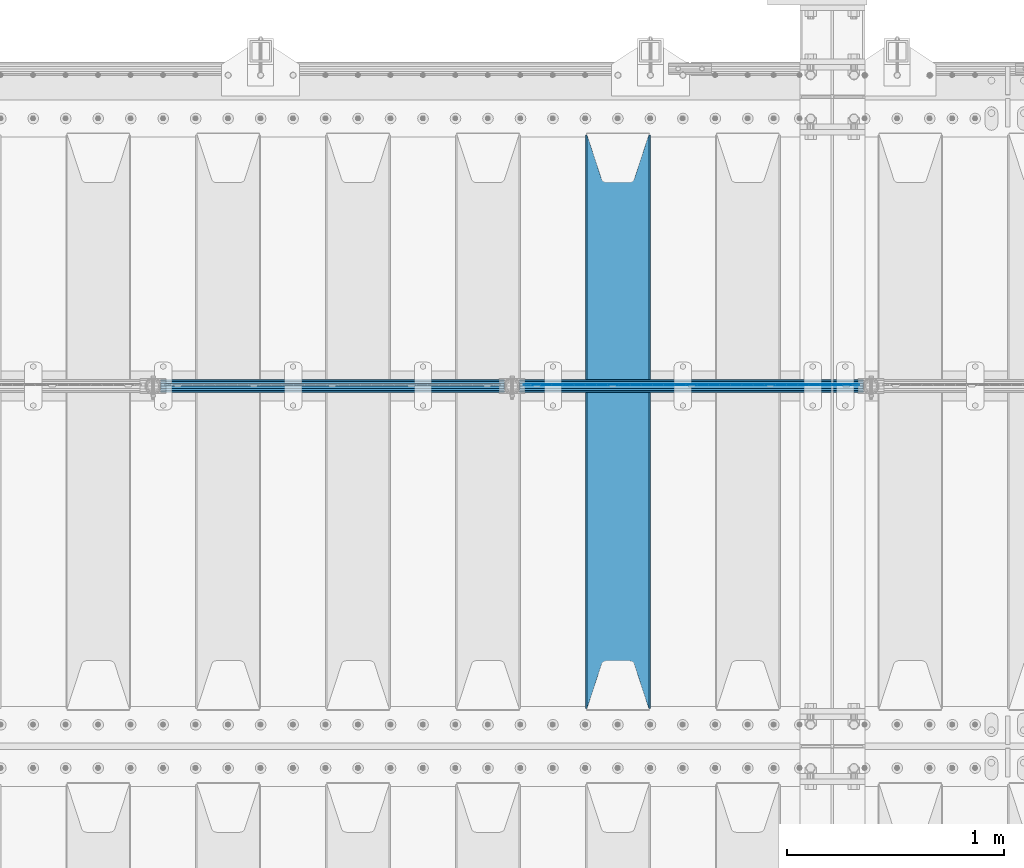
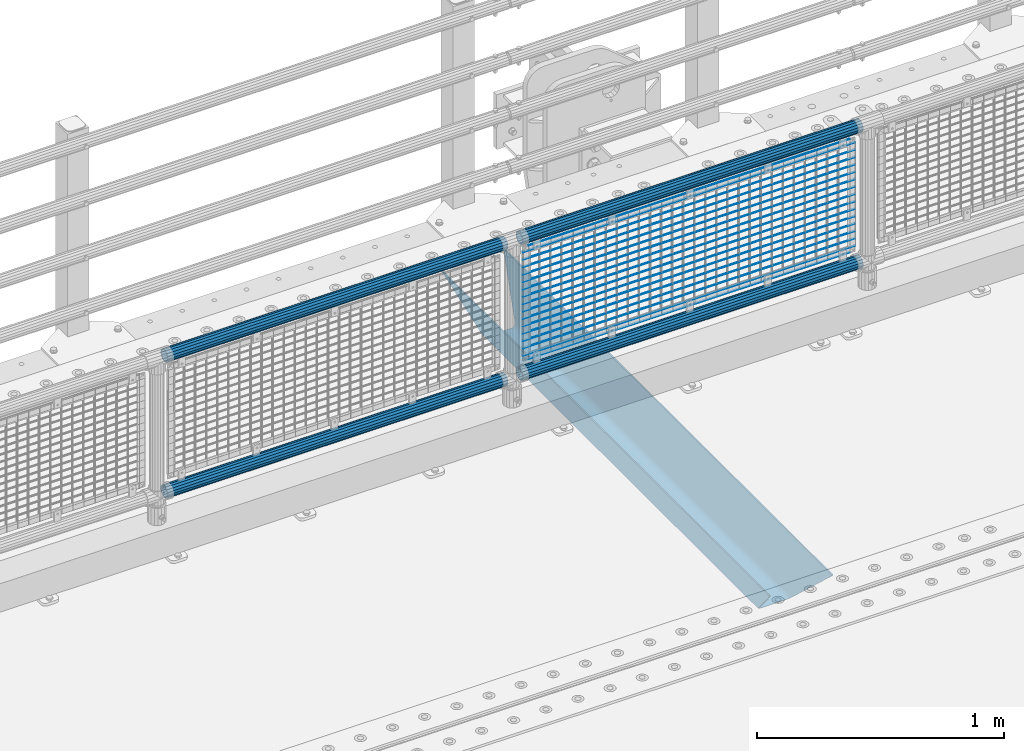
# One storey, part 122 of 240: 22 beams.
"""IFC2X3 building model written with IfcOpenShell, lengths in millimetres."""

from ifc_helpers import new_model, si_unit, frame, origin_with_axes, place, context, subcontext, project, spatial, faceted_brep, material, type_object, element, save


model = new_model("IFC2X3")

# Units and contexts
model_context = context("Model", 3, precision=1e-05, world=origin_with_axes())
body_context = subcontext(model_context, "Body", "Model", "MODEL_VIEW")
ifc_project = project(units=[si_unit("LENGTHUNIT", "METRE", prefix="MILLI"), si_unit("AREAUNIT", "SQUARE_METRE"), si_unit("VOLUMEUNIT", "CUBIC_METRE"), si_unit("MASSUNIT", "GRAM", prefix="KILO"), si_unit("TIMEUNIT", "SECOND"), si_unit("PLANEANGLEUNIT", "RADIAN"), si_unit("SOLIDANGLEUNIT", "STERADIAN"), si_unit("THERMODYNAMICTEMPERATUREUNIT", "DEGREE_CELSIUS"), si_unit("LUMINOUSINTENSITYUNIT", "LUMEN")], contexts=[model_context])

# Site, building, storey
site_placement = place(None, origin_with_axes())
site = spatial("IfcSite", under=ifc_project, at=site_placement, CompositionType="ELEMENT")
building_placement = place(site_placement, origin_with_axes())
building = spatial("IfcBuilding", under=site, at=building_placement, Name="Standard", CompositionType="ELEMENT")
storey_placement = place(building_placement, origin_with_axes())
storey = spatial("IfcBuildingStorey", under=building, at=storey_placement, Name="Undefined", CompositionType="ELEMENT", Elevation=0.0)

# Beams
ifc_material_1 = material(Name="STEEL/S355N")
beam_type_1 = type_object("IfcBeamType", PredefinedType="NOTDEFINED")
beam_1_placement = place(storey_placement, frame((51850.0, 33175.0, -115.0), z_axis=(0.0, 0.0, 1.0), x_axis=(0.0, 1.0, 0.0)))
element("IfcBeam", 1, at=beam_1_placement, inside=storey, type_object=beam_type_1, material=ifc_material_1, context=body_context, shape_type="Brep", body=[
    faceted_brep([(0.0, 150.0, 115.0), (0.0, 143.690000000002, 115.0), (2650.00000000297, 143.690000000002, 115.0), (2650.00000000297, 150.0, 115.0), (2650.00000000297, 142.059565218406, 110.000000003094), (2650.00000000297, 148.369565218403, 110.000000003094), (2441.90079219209, -80.1103600731149, -98.0992078077845), (2437.7588105432, -77.5672621345584, -102.241189456673), (2434.06523489747, -74.4080125315522, -105.934765102404), (2430.9108609509, -70.7102721255724, -109.089139048974), (2428.37322971128, -66.5649389910031, -111.626770288588), (2426.51472138055, -62.0739139532889, -113.485278619323), (2425.38102192092, -57.3475956567636, -114.618978078955), (2424.99999999987, -52.5021667386536, -115.0), (2424.99999999987, 52.5021667386536, -115.0), (2425.38102192092, 57.3475956567636, -114.618978078955), (2426.51472138055, 62.0739139532889, -113.485278619323), (2428.37322971128, 66.5649389910031, -111.626770288588), (2430.9108609509, 70.7102721255724, -109.089139048974), (2434.06523489747, 74.4080125315522, -105.934765102404), (2437.7588105432, 77.5672621345584, -102.241189456673), (2441.90079219209, 80.1103600731149, -98.0992078077846), (2446.38936140512, 81.9747917625791, -93.6106385947584), (2448.2494850041, 76.2713538057287, -91.7505149957729), (2444.62967112263, 74.76777986261, -95.3703288772456), (2441.28936334127, 72.7168944282894, -98.710636658607), (2438.31067330439, 70.1691124903809, -101.689326695487), (2435.76682334748, 67.1870637758839, -104.233176652398), (2433.72034654134, 63.8440531834931, -106.279653458539), (2432.22154950042, 60.2222587982324, -107.778450499454), (2431.30727574265, 56.4107117849126, -108.692724257221), (2430.99999999987, 52.5031078186876, -109.0), (2430.99999999987, -52.5031078186876, -109.0), (2431.30727574265, -56.4107117849126, -108.692724257221), (2432.22154950042, -60.2222587982324, -107.778450499454), (2433.72034654134, -63.8440531834931, -106.279653458539), (2435.76682334748, -67.1870637758839, -104.233176652398), (2438.31067330439, -70.1691124903809, -101.689326695487), (2441.28936334127, -72.7168944282894, -98.7106366586071), (2444.62967112263, -74.76777986261, -95.3703288772457), (2448.2494850041, -76.2713538057287, -91.7505149957729), (2650.00000000297, -142.059565218406, 110.000000003094), (2650.00000000297, -148.369565218403, 110.000000003094), (2446.38936140512, -81.9747917625791, -93.6106385947584), (2650.00000000297, -143.690000000002, 115.0), (2650.00000000297, -150.0, 115.0), (0.0, -143.690000000002, 115.0), (0.0, -150.0, 115.0), (0.0, -148.369565218258, 110.000000002667), (203.610638597427, -81.9747917625791, -93.6106385947584), (208.09920781045, -80.1103600731149, -98.0992078077845), (212.241189459342, -77.5672621345584, -102.241189456673), (215.93476510507, -74.4080125315522, -105.934765102404), (219.089139051641, -70.7102721255724, -109.089139048974), (221.626770291256, -66.5649389910031, -111.626770288588), (223.485278621989, -62.0739139532889, -113.485278619323), (224.618978081624, -57.3475956567636, -114.618978078955), (225.000000002663, -52.5021667386536, -115.0), (225.000000002663, 52.5021667386536, -115.0), (224.618978081624, 57.3475956567636, -114.618978078955), (223.485278621989, 62.0739139532889, -113.485278619323), (221.626770291256, 66.5649389910031, -111.626770288588), (219.089139051641, 70.7102721255724, -109.089139048974), (215.93476510507, 74.4080125315522, -105.934765102404), (212.241189459342, 77.5672621345584, -102.241189456673), (208.09920781045, 80.1103600731149, -98.0992078077846), (203.610638597427, 81.9747917625791, -93.6106385947584), (0.0, 148.369565218258, 110.000000002667), (0.0, 142.05956521826, 110.000000002667), (201.750514998439, 76.2713538057287, -91.7505149957729), (205.370328879908, 74.76777986261, -95.3703288772456), (208.710636661275, 72.7168944282894, -98.710636658607), (211.689326698153, 70.1691124903809, -101.689326695487), (214.233176655063, 67.1870637758839, -104.233176652398), (216.279653461206, 63.8440531834931, -106.279653458539), (217.778450502123, 60.2222587982324, -107.778450499454), (218.692724259887, 56.4107117849126, -108.692724257221), (219.000000002667, 52.5031078186876, -109.0), (219.000000002667, -52.5031078186876, -109.0), (218.692724259887, -56.4107117849126, -108.692724257221), (217.778450502123, -60.2222587982324, -107.778450499454), (216.279653461206, -63.8440531834931, -106.279653458539), (214.233176655063, -67.1870637758839, -104.233176652398), (211.689326698153, -70.1691124903809, -101.689326695487), (208.710636661275, -72.7168944282894, -98.7106366586071), (205.370328879915, -74.76777986261, -95.3703288772457), (201.750514998439, -76.2713538057287, -91.7505149957729), (0.0, -142.05956521826, 110.000000002667)], [[[0, 1, 2, 3]], [[3, 2, 4, 5]], [[6, 7, 8, 9, 10, 11, 12, 13, 14, 15, 16, 17, 18, 19, 20, 21, 22, 5, 4, 23, 24, 25, 26, 27, 28, 29, 30, 31, 32, 33, 34, 35, 36, 37, 38, 39, 40, 41, 42, 43]], [[44, 45, 42, 41]], [[46, 47, 45, 44]], [[43, 42, 45, 47, 48, 49]], [[6, 43, 49, 50]], [[7, 6, 50, 51]], [[8, 7, 51, 52]], [[9, 8, 52, 53]], [[10, 9, 53, 54]], [[11, 10, 54, 55]], [[12, 11, 55, 56]], [[13, 12, 56, 57]], [[14, 13, 57, 58]], [[15, 14, 58, 59]], [[16, 15, 59, 60]], [[17, 16, 60, 61]], [[18, 17, 61, 62]], [[19, 18, 62, 63]], [[20, 19, 63, 64]], [[21, 20, 64, 65]], [[22, 21, 65, 66]], [[0, 3, 5, 22, 66, 67]], [[1, 0, 67, 68]], [[23, 4, 2, 1, 68, 69]], [[24, 23, 69, 70]], [[25, 24, 70, 71]], [[26, 25, 71, 72]], [[27, 26, 72, 73]], [[28, 27, 73, 74]], [[29, 28, 74, 75]], [[30, 29, 75, 76]], [[31, 30, 76, 77]], [[32, 31, 77, 78]], [[33, 32, 78, 79]], [[34, 33, 79, 80]], [[35, 34, 80, 81]], [[36, 35, 81, 82]], [[37, 36, 82, 83]], [[38, 37, 83, 84]], [[39, 38, 84, 85]], [[40, 39, 85, 86]], [[46, 44, 41, 40, 86, 87]], [[47, 46, 87, 48]], [[86, 85, 84, 83, 82, 81, 80, 79, 78, 77, 76, 75, 74, 73, 72, 71, 70, 69, 68, 67, 66, 65, 64, 63, 62, 61, 60, 59, 58, 57, 56, 55, 54, 53, 52, 51, 50, 49, 48, 87]]]),
])
ifc_material_2 = material(Name="Misc_Undefined")
beam_type_2 = type_object("IfcBeamType", Name="D3", PredefinedType="NOTDEFINED")
for number, where, z_axis, x_axis in (
    (2, (51416.0, 34670.5, 851.597000000001), (0.0, 0.0, 1.0), (1.0, 0.0, 0.0)),
    (3, (51416.0, 34670.5, 669.452000000001), (0.0, 0.0, 1.0), (1.0, 0.0, 0.0)),
    (4, (51416.0, 34670.5, 523.736000000001), (0.0, 0.0, 1.0), (1.0, 0.0, 0.0)),
    (5, (51416.0, 34670.5, 487.307000000001), (0.0, 0.0, 1.0), (1.0, 0.0, 0.0)),
    (6, (51416.0, 34670.5, 705.881000000001), (0.0, 0.0, 1.0), (1.0, 0.0, 0.0)),
    (7, (51416.0, 34670.5, 596.594000000001), (0.0, 0.0, 1.0), (1.0, 0.0, 0.0)),
    (8, (51416.0, 34670.5, 450.878000000001), (0.0, 0.0, 1.0), (1.0, 0.0, 0.0)),
    (9, (51416.0, 34670.5, 815.168000000001), (0.0, 0.0, 1.0), (1.0, 0.0, 0.0)),
    (10, (51416.0, 34670.5, 888.026000000001), (0.0, 0.0, 1.0), (1.0, 0.0, 0.0)),
    (11, (51416.0, 34670.5, 778.739000000001), (0.0, 0.0, 1.0), (1.0, 0.0, 0.0)),
    (12, (51416.0, 34670.5, 742.310000000001), (0.0, 0.0, 1.0), (1.0, 0.0, 0.0)),
    (13, (51416.0, 34670.5, 633.023000000001), (0.0, 0.0, 1.0), (1.0, 0.0, 0.0)),
    (14, (51416.0, 34670.5, 560.165000000001), (0.0, 0.0, 1.0), (1.0, 0.0, 0.0)),
    (15, (51416.0, 34670.5, 414.449000000001), (0.0, 0.0, 1.0), (1.0, 0.0, 0.0)),
):
    element("IfcBeam", number, at=place(storey_placement, frame(where, z_axis=z_axis, x_axis=x_axis)), inside=storey, type_object=beam_type_2, material=ifc_material_2, ObjectType="D3", context=body_context, shape_type="Brep", body=[
        faceted_brep([(-7.27595761418343e-12, -1.49999999999272, 0.0), (-7.27595761418343e-12, -0.749999999992724, -1.29903810567669), (1548.0, -0.75, -1.29903810567669), (1548.0, -1.5, 0.0), (0.0, 0.750000000007276, -1.29903810567669), (1548.0, 0.75, -1.29903810567669), (0.0, 1.50000000000728, 0.0), (1548.0, 1.5, 0.0), (0.0, 0.750000000007276, 1.29903810567669), (1548.0, 0.75, 1.29903810567669), (-7.27595761418343e-12, -0.749999999992724, 1.29903810567669), (1548.0, -0.75, 1.29903810567669)], [[[0, 1, 2, 3]], [[1, 4, 5, 2]], [[4, 6, 7, 5]], [[6, 8, 9, 7]], [[8, 10, 11, 9]], [[10, 0, 3, 11]], [[5, 7, 9, 11, 3, 2]], [[10, 8, 6, 4, 1, 0]]]),
    ])
beam_2_placement = place(storey_placement, frame((51441.0, 34670.5, 353.020000000001), z_axis=(0.0, 0.0, 1.0), x_axis=(1.0, 0.0, 0.0)))
element("IfcBeam", 16, at=beam_2_placement, inside=storey, type_object=beam_type_2, material=ifc_material_2, ObjectType="D3", context=body_context, shape_type="Brep", body=[
    faceted_brep([(-7.27595761418343e-12, -1.49999999999272, 0.0), (-7.27595761418343e-12, -0.749999999992724, -1.29903810567669), (1498.0, -0.75, -1.29903810567669), (1498.0, -1.5, 0.0), (0.0, 0.750000000007276, -1.29903810567669), (1498.0, 0.75, -1.29903810567663), (0.0, 1.50000000000728, 0.0), (1498.0, 1.5, 0.0), (0.0, 0.750000000007276, 1.29903810567669), (1498.0, 0.75, 1.29903810567669), (-7.27595761418343e-12, -0.749999999992724, 1.29903810567669), (1498.0, -0.75, 1.29903810567669)], [[[0, 1, 2, 3]], [[1, 4, 5, 2]], [[4, 6, 7, 5]], [[6, 8, 9, 7]], [[8, 10, 11, 9]], [[10, 0, 3, 11]], [[5, 7, 9, 11, 3, 2]], [[10, 8, 6, 4, 1, 0]]]),
])
beam_3_placement = place(storey_placement, frame((51416.0, 34670.5, 378.020000000001), z_axis=(0.0, 0.0, 1.0), x_axis=(1.0, 0.0, 0.0)))
element("IfcBeam", 17, at=beam_3_placement, inside=storey, type_object=beam_type_2, material=ifc_material_2, ObjectType="D3", context=body_context, shape_type="Brep", body=[
    faceted_brep([(-7.27595761418343e-12, -1.49999999999272, 0.0), (-7.27595761418343e-12, -0.749999999992724, -1.29903810567669), (1548.0, -0.75, -1.29903810567669), (1548.0, -1.5, 0.0), (0.0, 0.750000000007276, -1.29903810567669), (1548.0, 0.75, -1.29903810567669), (0.0, 1.50000000000728, 0.0), (1548.0, 1.5, 0.0), (0.0, 0.750000000007276, 1.29903810567669), (1548.0, 0.75, 1.29903810567669), (-7.27595761418343e-12, -0.749999999992724, 1.29903810567669), (1548.0, -0.75, 1.29903810567669)], [[[0, 1, 2, 3]], [[1, 4, 5, 2]], [[4, 6, 7, 5]], [[6, 8, 9, 7]], [[8, 10, 11, 9]], [[10, 0, 3, 11]], [[5, 7, 9, 11, 3, 2]], [[10, 8, 6, 4, 1, 0]]]),
])
beam_4_placement = place(storey_placement, frame((51441.0, 34670.5, 913.020000000001), z_axis=(0.0, 0.0, 1.0), x_axis=(1.0, 0.0, 0.0)))
element("IfcBeam", 18, at=beam_4_placement, inside=storey, type_object=beam_type_2, material=ifc_material_2, ObjectType="D3", context=body_context, shape_type="Brep", body=[
    faceted_brep([(-7.27595761418343e-12, -1.49999999999272, 0.0), (-7.27595761418343e-12, -0.749999999992724, -1.29903810567669), (1498.0, -0.75, -1.29903810567669), (1498.0, -1.5, 0.0), (0.0, 0.750000000007276, -1.29903810567669), (1498.0, 0.75, -1.29903810567663), (0.0, 1.50000000000728, 0.0), (1498.0, 1.5, 0.0), (0.0, 0.750000000007276, 1.29903810567669), (1498.0, 0.75, 1.29903810567669), (-7.27595761418343e-12, -0.749999999992724, 1.29903810567669), (1498.0, -0.75, 1.29903810567669)], [[[0, 1, 2, 3]], [[1, 4, 5, 2]], [[4, 6, 7, 5]], [[6, 8, 9, 7]], [[8, 10, 11, 9]], [[10, 0, 3, 11]], [[5, 7, 9, 11, 3, 2]], [[10, 8, 6, 4, 1, 0]]]),
])
ifc_material_3 = material()
beam_type_3 = type_object("IfcBeamType", PredefinedType="NOTDEFINED")
beam_5_placement = place(storey_placement, frame((51395.85, 34664.5, 969.850000000001), z_axis=(0.0, 0.0, 1.0), x_axis=(1.0, 0.0, 0.0)))
element("IfcBeam", 19, at=beam_5_placement, inside=storey, type_object=beam_type_3, material=ifc_material_3, context=body_context, shape_type="Brep", body=[
    faceted_brep([(0.0, -25.3499999999985, 0.0), (0.0, -23.4203461491634, 9.70102501045767), (1588.0, -23.4203461491634, 9.70102501045506), (1588.0, -25.3499999999985, 0.0), (0.0, -17.9251569030821, 17.9251569030821), (1588.0, -17.9251569030821, 17.925156903079), (0.0, -9.70102501045767, 23.4203461491634), (1588.0, -9.70102501045767, 23.4203461491611), (0.0, 0.0, 25.3499999999985), (1588.0, 0.0, 25.35), (0.0, 9.70102501045767, 23.4203461491634), (1588.0, 9.70102501045767, 23.4203461491611), (0.0, 17.9251569030821, 17.9251569030821), (1588.0, 17.9251569030821, 17.925156903079), (0.0, 23.4203461491634, 9.70102501045767), (1588.0, 23.4203461491634, 9.70102501045506), (0.0, 25.3499999999985, 0.0), (1588.0, 25.3499999999985, 0.0), (0.0, 23.4203461491634, -9.70102501045767), (1588.0, 23.4203461491634, -9.70102501045506), (0.0, 17.9251569030821, -17.9251569030821), (1588.0, 17.9251569030821, -17.925156903079), (0.0, 9.70102501045767, -23.4203461491634), (1588.0, 9.70102501045767, -23.4203461491611), (0.0, 0.0, -25.3499999999985), (1588.0, 0.0, -25.35), (0.0, -9.70102501045767, -23.4203461491634), (1588.0, -9.70102501045767, -23.4203461491611), (0.0, -17.9251569030821, -17.9251569030821), (1588.0, -17.9251569030821, -17.925156903079), (0.0, -23.4203461491634, -9.70102501045767), (1588.0, -23.4203461491634, -9.70102501045506), (0.0, -30.1500000000015, 0.0), (0.0, -27.8549679052157, -11.5379054858058), (1588.0, -27.8549679052157, -11.5379054858075), (1588.0, -30.1500000000015, 0.0), (0.0, -21.3192694527752, -21.3192694527752), (1588.0, -21.3192694527752, -21.3192694527744), (0.0, -11.5379054858058, -27.8549679052157), (1588.0, -11.5379054858058, -27.8549679052153), (0.0, 0.0, -30.1500000000015), (1588.0, 0.0, -30.15), (0.0, 11.5379054858058, -27.8549679052157), (1588.0, 11.5379054858058, -27.8549679052153), (0.0, 21.3192694527752, -21.3192694527752), (1588.0, 21.3192694527752, -21.3192694527744), (0.0, 27.8549679052157, -11.5379054858058), (1588.0, 27.8549679052157, -11.5379054858074), (0.0, 30.1500000000015, 0.0), (1588.0, 30.1500000000015, 0.0), (0.0, 27.8549679052157, 11.5379054858058), (1588.0, 27.8549679052157, 11.5379054858074), (0.0, 21.3192694527752, 21.3192694527752), (1588.0, 21.3192694527752, 21.3192694527744), (0.0, 11.5379054858058, 27.8549679052157), (1588.0, 11.5379054858058, 27.8549679052153), (0.0, 0.0, 30.1500000000015), (1588.0, 0.0, 30.15), (0.0, -11.5379054858058, 27.8549679052157), (1588.0, -11.5379054858058, 27.8549679052153), (0.0, -21.3192694527752, 21.3192694527752), (1588.0, -21.3192694527752, 21.3192694527744), (0.0, -27.8549679052157, 11.5379054858058), (1588.0, -27.8549679052157, 11.5379054858074)], [[[0, 1, 2, 3]], [[1, 4, 5, 2]], [[4, 6, 7, 5]], [[6, 8, 9, 7]], [[8, 10, 11, 9]], [[10, 12, 13, 11]], [[12, 14, 15, 13]], [[14, 16, 17, 15]], [[16, 18, 19, 17]], [[18, 20, 21, 19]], [[20, 22, 23, 21]], [[22, 24, 25, 23]], [[24, 26, 27, 25]], [[26, 28, 29, 27]], [[28, 30, 31, 29]], [[30, 0, 3, 31]], [[32, 33, 34, 35]], [[33, 36, 37, 34]], [[36, 38, 39, 37]], [[38, 40, 41, 39]], [[40, 42, 43, 41]], [[42, 44, 45, 43]], [[44, 46, 47, 45]], [[46, 48, 49, 47]], [[48, 50, 51, 49]], [[50, 52, 53, 51]], [[52, 54, 55, 53]], [[54, 56, 57, 55]], [[56, 58, 59, 57]], [[58, 60, 61, 59]], [[60, 62, 63, 61]], [[62, 32, 35, 63]], [[37, 39, 41, 43, 45, 47, 49, 51, 53, 55, 57, 59, 61, 63, 35, 34], [5, 7, 9, 11, 13, 15, 17, 19, 21, 23, 25, 27, 29, 31, 3, 2]], [[62, 60, 58, 56, 54, 52, 50, 48, 46, 44, 42, 40, 38, 36, 33, 32], [30, 28, 26, 24, 22, 20, 18, 16, 14, 12, 10, 8, 6, 4, 1, 0]]]),
])
beam_6_placement = place(storey_placement, frame((51395.85, 34664.5, 298.170000000002), z_axis=(0.0, 0.0, 1.0), x_axis=(1.0, 0.0, 0.0)))
element("IfcBeam", 20, at=beam_6_placement, inside=storey, type_object=beam_type_3, material=ifc_material_3, context=body_context, shape_type="Brep", body=[
    faceted_brep([(0.0, -25.3499999999985, 0.0), (0.0, -23.4203461491634, 9.70102501045767), (1588.0, -23.4203461491634, 9.70102501045506), (1588.0, -25.3499999999985, 0.0), (0.0, -17.9251569030821, 17.9251569030821), (1588.0, -17.9251569030821, 17.925156903079), (0.0, -9.70102501045767, 23.4203461491634), (1588.0, -9.70102501045767, 23.4203461491611), (0.0, 0.0, 25.3499999999985), (1588.0, 0.0, 25.35), (0.0, 9.70102501045767, 23.4203461491634), (1588.0, 9.70102501045767, 23.4203461491611), (0.0, 17.9251569030821, 17.9251569030821), (1588.0, 17.9251569030821, 17.925156903079), (0.0, 23.4203461491634, 9.70102501045767), (1588.0, 23.4203461491634, 9.70102501045506), (0.0, 25.3499999999985, 0.0), (1588.0, 25.3499999999985, 0.0), (0.0, 23.4203461491634, -9.70102501045767), (1588.0, 23.4203461491634, -9.70102501045506), (0.0, 17.9251569030821, -17.9251569030821), (1588.0, 17.9251569030821, -17.925156903079), (0.0, 9.70102501045767, -23.4203461491634), (1588.0, 9.70102501045767, -23.4203461491611), (0.0, 0.0, -25.3499999999985), (1588.0, 0.0, -25.35), (0.0, -9.70102501045767, -23.4203461491634), (1588.0, -9.70102501045767, -23.4203461491611), (0.0, -17.9251569030821, -17.9251569030821), (1588.0, -17.9251569030821, -17.925156903079), (0.0, -23.4203461491634, -9.70102501045767), (1588.0, -23.4203461491634, -9.70102501045506), (0.0, -30.1500000000015, 0.0), (0.0, -27.8549679052157, -11.5379054858058), (1588.0, -27.8549679052157, -11.5379054858075), (1588.0, -30.1500000000015, 0.0), (0.0, -21.3192694527752, -21.3192694527752), (1588.0, -21.3192694527752, -21.3192694527744), (0.0, -11.5379054858058, -27.8549679052157), (1588.0, -11.5379054858058, -27.8549679052153), (0.0, 0.0, -30.1500000000015), (1588.0, 0.0, -30.15), (0.0, 11.5379054858058, -27.8549679052157), (1588.0, 11.5379054858058, -27.8549679052153), (0.0, 21.3192694527752, -21.3192694527752), (1588.0, 21.3192694527752, -21.3192694527744), (0.0, 27.8549679052157, -11.5379054858058), (1588.0, 27.8549679052157, -11.5379054858074), (0.0, 30.1500000000015, 0.0), (1588.0, 30.1500000000015, 0.0), (0.0, 27.8549679052157, 11.5379054858058), (1588.0, 27.8549679052157, 11.5379054858074), (0.0, 21.3192694527752, 21.3192694527752), (1588.0, 21.3192694527752, 21.3192694527744), (0.0, 11.5379054858058, 27.8549679052157), (1588.0, 11.5379054858058, 27.8549679052153), (0.0, 0.0, 30.1500000000015), (1588.0, 0.0, 30.15), (0.0, -11.5379054858058, 27.8549679052157), (1588.0, -11.5379054858058, 27.8549679052153), (0.0, -21.3192694527752, 21.3192694527752), (1588.0, -21.3192694527752, 21.3192694527744), (0.0, -27.8549679052157, 11.5379054858058), (1588.0, -27.8549679052157, 11.5379054858074)], [[[0, 1, 2, 3]], [[1, 4, 5, 2]], [[4, 6, 7, 5]], [[6, 8, 9, 7]], [[8, 10, 11, 9]], [[10, 12, 13, 11]], [[12, 14, 15, 13]], [[14, 16, 17, 15]], [[16, 18, 19, 17]], [[18, 20, 21, 19]], [[20, 22, 23, 21]], [[22, 24, 25, 23]], [[24, 26, 27, 25]], [[26, 28, 29, 27]], [[28, 30, 31, 29]], [[30, 0, 3, 31]], [[32, 33, 34, 35]], [[33, 36, 37, 34]], [[36, 38, 39, 37]], [[38, 40, 41, 39]], [[40, 42, 43, 41]], [[42, 44, 45, 43]], [[44, 46, 47, 45]], [[46, 48, 49, 47]], [[48, 50, 51, 49]], [[50, 52, 53, 51]], [[52, 54, 55, 53]], [[54, 56, 57, 55]], [[56, 58, 59, 57]], [[58, 60, 61, 59]], [[60, 62, 63, 61]], [[62, 32, 35, 63]], [[37, 39, 41, 43, 45, 47, 49, 51, 53, 55, 57, 59, 61, 63, 35, 34], [5, 7, 9, 11, 13, 15, 17, 19, 21, 23, 25, 27, 29, 31, 3, 2]], [[62, 60, 58, 56, 54, 52, 50, 48, 46, 44, 42, 40, 38, 36, 33, 32], [30, 28, 26, 24, 22, 20, 18, 16, 14, 12, 10, 8, 6, 4, 1, 0]]]),
])
beam_7_placement = place(storey_placement, frame((49737.85, 34664.5, 969.850000000001), z_axis=(0.0, 0.0, 1.0), x_axis=(1.0, 0.0, 0.0)))
element("IfcBeam", 21, at=beam_7_placement, inside=storey, type_object=beam_type_3, material=ifc_material_3, context=body_context, shape_type="Brep", body=[
    faceted_brep([(0.0, -25.3499999999985, 0.0), (0.0, -23.4203461491634, 9.70102501045767), (1588.0, -23.4203461491634, 9.70102501045506), (1588.0, -25.3499999999985, 0.0), (0.0, -17.9251569030821, 17.9251569030821), (1588.0, -17.9251569030821, 17.925156903079), (0.0, -9.70102501045767, 23.4203461491634), (1588.0, -9.70102501045767, 23.4203461491611), (0.0, 0.0, 25.3499999999985), (1588.0, 0.0, 25.35), (0.0, 9.70102501045767, 23.4203461491634), (1588.0, 9.70102501045767, 23.4203461491611), (0.0, 17.9251569030821, 17.9251569030821), (1588.0, 17.9251569030821, 17.925156903079), (0.0, 23.4203461491634, 9.70102501045767), (1588.0, 23.4203461491634, 9.70102501045506), (0.0, 25.3499999999985, 0.0), (1588.0, 25.3499999999985, 0.0), (0.0, 23.4203461491634, -9.70102501045767), (1588.0, 23.4203461491634, -9.70102501045506), (0.0, 17.9251569030821, -17.9251569030821), (1588.0, 17.9251569030821, -17.925156903079), (0.0, 9.70102501045767, -23.4203461491634), (1588.0, 9.70102501045767, -23.4203461491611), (0.0, 0.0, -25.3499999999985), (1588.0, 0.0, -25.35), (0.0, -9.70102501045767, -23.4203461491634), (1588.0, -9.70102501045767, -23.4203461491611), (0.0, -17.9251569030821, -17.9251569030821), (1588.0, -17.9251569030821, -17.925156903079), (0.0, -23.4203461491634, -9.70102501045767), (1588.0, -23.4203461491634, -9.70102501045506), (0.0, -30.1500000000015, 0.0), (0.0, -27.8549679052157, -11.5379054858058), (1588.0, -27.8549679052157, -11.5379054858075), (1588.0, -30.1500000000015, 0.0), (0.0, -21.3192694527752, -21.3192694527752), (1588.0, -21.3192694527752, -21.3192694527744), (0.0, -11.5379054858058, -27.8549679052157), (1588.0, -11.5379054858058, -27.8549679052153), (0.0, 0.0, -30.1500000000015), (1588.0, 0.0, -30.15), (0.0, 11.5379054858058, -27.8549679052157), (1588.0, 11.5379054858058, -27.8549679052153), (0.0, 21.3192694527752, -21.3192694527752), (1588.0, 21.3192694527752, -21.3192694527744), (0.0, 27.8549679052157, -11.5379054858058), (1588.0, 27.8549679052157, -11.5379054858074), (0.0, 30.1500000000015, 0.0), (1588.0, 30.1500000000015, 0.0), (0.0, 27.8549679052157, 11.5379054858058), (1588.0, 27.8549679052157, 11.5379054858074), (0.0, 21.3192694527752, 21.3192694527752), (1588.0, 21.3192694527752, 21.3192694527744), (0.0, 11.5379054858058, 27.8549679052157), (1588.0, 11.5379054858058, 27.8549679052153), (0.0, 0.0, 30.1500000000015), (1588.0, 0.0, 30.15), (0.0, -11.5379054858058, 27.8549679052157), (1588.0, -11.5379054858058, 27.8549679052153), (0.0, -21.3192694527752, 21.3192694527752), (1588.0, -21.3192694527752, 21.3192694527744), (0.0, -27.8549679052157, 11.5379054858058), (1588.0, -27.8549679052157, 11.5379054858074)], [[[0, 1, 2, 3]], [[1, 4, 5, 2]], [[4, 6, 7, 5]], [[6, 8, 9, 7]], [[8, 10, 11, 9]], [[10, 12, 13, 11]], [[12, 14, 15, 13]], [[14, 16, 17, 15]], [[16, 18, 19, 17]], [[18, 20, 21, 19]], [[20, 22, 23, 21]], [[22, 24, 25, 23]], [[24, 26, 27, 25]], [[26, 28, 29, 27]], [[28, 30, 31, 29]], [[30, 0, 3, 31]], [[32, 33, 34, 35]], [[33, 36, 37, 34]], [[36, 38, 39, 37]], [[38, 40, 41, 39]], [[40, 42, 43, 41]], [[42, 44, 45, 43]], [[44, 46, 47, 45]], [[46, 48, 49, 47]], [[48, 50, 51, 49]], [[50, 52, 53, 51]], [[52, 54, 55, 53]], [[54, 56, 57, 55]], [[56, 58, 59, 57]], [[58, 60, 61, 59]], [[60, 62, 63, 61]], [[62, 32, 35, 63]], [[37, 39, 41, 43, 45, 47, 49, 51, 53, 55, 57, 59, 61, 63, 35, 34], [5, 7, 9, 11, 13, 15, 17, 19, 21, 23, 25, 27, 29, 31, 3, 2]], [[62, 60, 58, 56, 54, 52, 50, 48, 46, 44, 42, 40, 38, 36, 33, 32], [30, 28, 26, 24, 22, 20, 18, 16, 14, 12, 10, 8, 6, 4, 1, 0]]]),
])
beam_8_placement = place(storey_placement, frame((49737.85, 34664.5, 298.170000000002), z_axis=(0.0, 0.0, 1.0), x_axis=(1.0, 0.0, 0.0)))
element("IfcBeam", 22, at=beam_8_placement, inside=storey, type_object=beam_type_3, material=ifc_material_3, context=body_context, shape_type="Brep", body=[
    faceted_brep([(0.0, -25.3499999999985, 0.0), (0.0, -23.4203461491634, 9.70102501045767), (1588.0, -23.4203461491634, 9.70102501045506), (1588.0, -25.3499999999985, 0.0), (0.0, -17.9251569030821, 17.9251569030821), (1588.0, -17.9251569030821, 17.925156903079), (0.0, -9.70102501045767, 23.4203461491634), (1588.0, -9.70102501045767, 23.4203461491611), (0.0, 0.0, 25.3499999999985), (1588.0, 0.0, 25.35), (0.0, 9.70102501045767, 23.4203461491634), (1588.0, 9.70102501045767, 23.4203461491611), (0.0, 17.9251569030821, 17.9251569030821), (1588.0, 17.9251569030821, 17.925156903079), (0.0, 23.4203461491634, 9.70102501045767), (1588.0, 23.4203461491634, 9.70102501045506), (0.0, 25.3499999999985, 0.0), (1588.0, 25.3499999999985, 0.0), (0.0, 23.4203461491634, -9.70102501045767), (1588.0, 23.4203461491634, -9.70102501045506), (0.0, 17.9251569030821, -17.9251569030821), (1588.0, 17.9251569030821, -17.925156903079), (0.0, 9.70102501045767, -23.4203461491634), (1588.0, 9.70102501045767, -23.4203461491611), (0.0, 0.0, -25.3499999999985), (1588.0, 0.0, -25.35), (0.0, -9.70102501045767, -23.4203461491634), (1588.0, -9.70102501045767, -23.4203461491611), (0.0, -17.9251569030821, -17.9251569030821), (1588.0, -17.9251569030821, -17.925156903079), (0.0, -23.4203461491634, -9.70102501045767), (1588.0, -23.4203461491634, -9.70102501045506), (0.0, -30.1500000000015, 0.0), (0.0, -27.8549679052157, -11.5379054858058), (1588.0, -27.8549679052157, -11.5379054858075), (1588.0, -30.1500000000015, 0.0), (0.0, -21.3192694527752, -21.3192694527752), (1588.0, -21.3192694527752, -21.3192694527744), (0.0, -11.5379054858058, -27.8549679052157), (1588.0, -11.5379054858058, -27.8549679052153), (0.0, 0.0, -30.1500000000015), (1588.0, 0.0, -30.15), (0.0, 11.5379054858058, -27.8549679052157), (1588.0, 11.5379054858058, -27.8549679052153), (0.0, 21.3192694527752, -21.3192694527752), (1588.0, 21.3192694527752, -21.3192694527744), (0.0, 27.8549679052157, -11.5379054858058), (1588.0, 27.8549679052157, -11.5379054858074), (0.0, 30.1500000000015, 0.0), (1588.0, 30.1500000000015, 0.0), (0.0, 27.8549679052157, 11.5379054858058), (1588.0, 27.8549679052157, 11.5379054858074), (0.0, 21.3192694527752, 21.3192694527752), (1588.0, 21.3192694527752, 21.3192694527744), (0.0, 11.5379054858058, 27.8549679052157), (1588.0, 11.5379054858058, 27.8549679052153), (0.0, 0.0, 30.1500000000015), (1588.0, 0.0, 30.15), (0.0, -11.5379054858058, 27.8549679052157), (1588.0, -11.5379054858058, 27.8549679052153), (0.0, -21.3192694527752, 21.3192694527752), (1588.0, -21.3192694527752, 21.3192694527744), (0.0, -27.8549679052157, 11.5379054858058), (1588.0, -27.8549679052157, 11.5379054858074)], [[[0, 1, 2, 3]], [[1, 4, 5, 2]], [[4, 6, 7, 5]], [[6, 8, 9, 7]], [[8, 10, 11, 9]], [[10, 12, 13, 11]], [[12, 14, 15, 13]], [[14, 16, 17, 15]], [[16, 18, 19, 17]], [[18, 20, 21, 19]], [[20, 22, 23, 21]], [[22, 24, 25, 23]], [[24, 26, 27, 25]], [[26, 28, 29, 27]], [[28, 30, 31, 29]], [[30, 0, 3, 31]], [[32, 33, 34, 35]], [[33, 36, 37, 34]], [[36, 38, 39, 37]], [[38, 40, 41, 39]], [[40, 42, 43, 41]], [[42, 44, 45, 43]], [[44, 46, 47, 45]], [[46, 48, 49, 47]], [[48, 50, 51, 49]], [[50, 52, 53, 51]], [[52, 54, 55, 53]], [[54, 56, 57, 55]], [[56, 58, 59, 57]], [[58, 60, 61, 59]], [[60, 62, 63, 61]], [[62, 32, 35, 63]], [[37, 39, 41, 43, 45, 47, 49, 51, 53, 55, 57, 59, 61, 63, 35, 34], [5, 7, 9, 11, 13, 15, 17, 19, 21, 23, 25, 27, 29, 31, 3, 2]], [[62, 60, 58, 56, 54, 52, 50, 48, 46, 44, 42, 40, 38, 36, 33, 32], [30, 28, 26, 24, 22, 20, 18, 16, 14, 12, 10, 8, 6, 4, 1, 0]]]),
])

save(model, "model.ifc")
